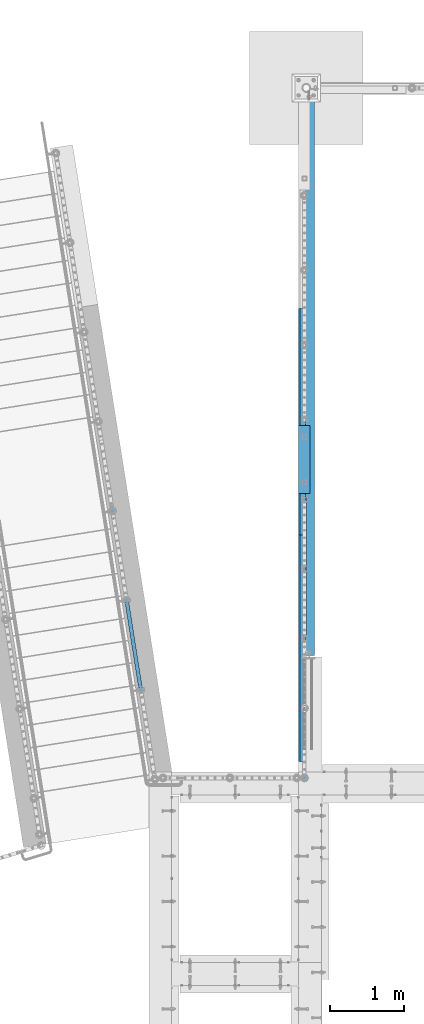
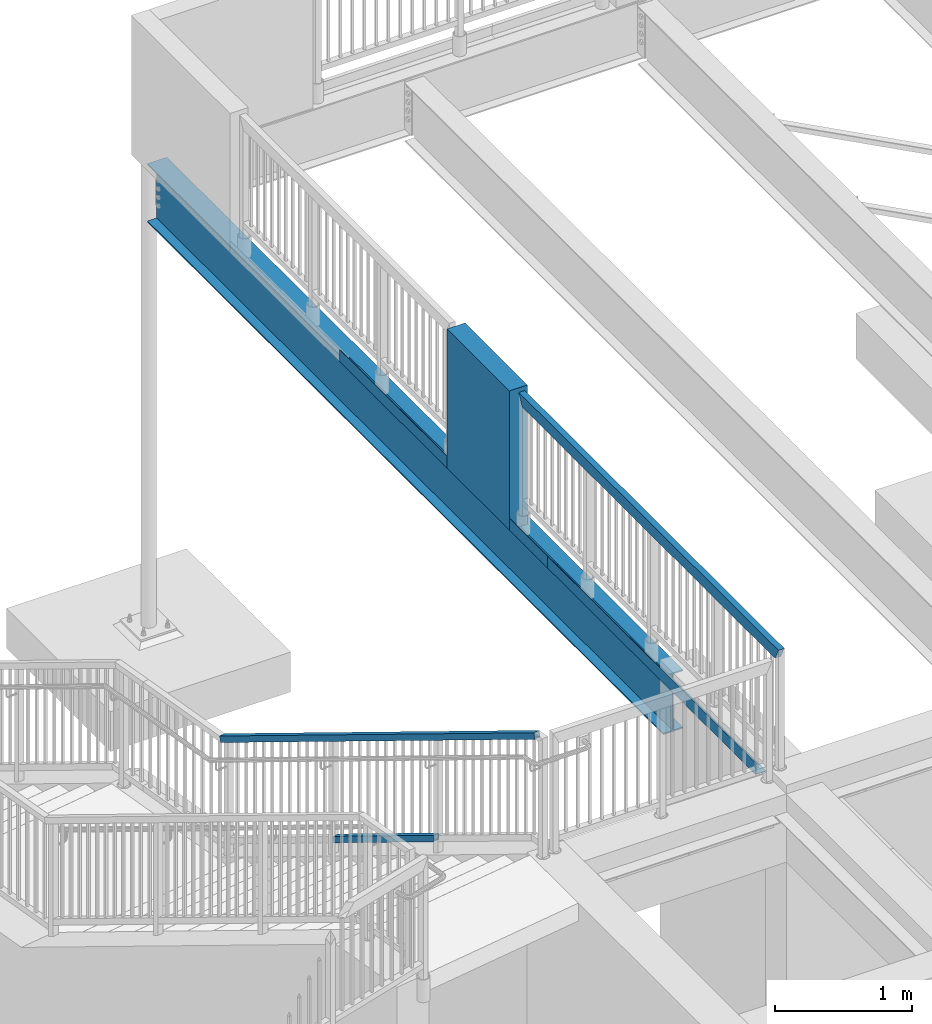
# One storey, part 322 of 975: 5 beams, 2 members.
"""IFC2X3 building model written with IfcOpenShell, lengths in millimetres."""

import ifcopenshell
import ifcopenshell.guid

model = None  # the IFC model being written
_history = None  # IfcOwnerHistory: only IFC2X3 demands one
_inside = {}  # id of a spatial element -> (the spatial element, [elements in it])
_under = {}  # id of a project, library or spatial element -> (it, [spatial elements below it])
_declared = {}  # id of a project -> (the project, [libraries it declares])
_typed = {}  # id of a type object -> (the type object, [elements of that type])
_made_of = {}  # id of a material, layer set ... -> (it, [elements and type objects made of it])


def new_model(schema):
    """Start an empty IFC model of exactly this schema.

    Asked for "IFC4X3", IfcOpenShell would pick the latest addendum, in which some entities
    have other attributes; the version numbers below select the first issue.
    IFC2X3 requires an IfcOwnerHistory on every rooted entity: one is made here for all.
    """
    global model, _history
    if schema == "IFC4X3":
        model = ifcopenshell.file(schema_version=(4, 3, 0, 0))
    else:
        model = ifcopenshell.file(schema=schema)
    _inside.clear()
    _under.clear()
    _declared.clear()
    _typed.clear()
    _made_of.clear()
    _history = None
    if model.schema == "IFC2X3":
        org = make("IfcOrganization", Name="unknown")
        user = make(
            "IfcPersonAndOrganization",
            ThePerson=make("IfcPerson", FamilyName="unknown"),
            TheOrganization=org,
        )
        app = make(
            "IfcApplication",
            ApplicationDeveloper=org,
            Version="unknown",
            ApplicationFullName="unknown",
            ApplicationIdentifier="unknown",
        )
        _history = make(
            "IfcOwnerHistory",
            OwningUser=user,
            OwningApplication=app,
            ChangeAction="ADDED",
            CreationDate=0,
        )
    return model


def make(cls, **values):
    """One entity of the class cls with the attributes given. An attribute that is None is left unset."""
    return model.create_entity(
        cls, **{name: value for name, value in values.items() if value is not None}
    )


def rooted(cls, **values):
    """An entity with a GlobalId (a new one), such as an element, a storey or a relation."""
    return make(cls, GlobalId=ifcopenshell.guid.new(), OwnerHistory=_history, **values)


def si_unit(unit_type, name, prefix=None):
    """IfcSIUnit, for example si_unit("LENGTHUNIT", "METRE", prefix="MILLI")."""
    return make("IfcSIUnit", UnitType=unit_type, Prefix=prefix, Name=name)


def assignment(units):
    """IfcUnitAssignment: the units of a project."""
    return None if units is None else make("IfcUnitAssignment", Units=units)


def point(xyz):
    """IfcCartesianPoint."""
    return None if xyz is None else make("IfcCartesianPoint", Coordinates=xyz)


def direction(xyz):
    """IfcDirection."""
    return None if xyz is None else make("IfcDirection", DirectionRatios=xyz)


def frame(location, z_axis=None, x_axis=None):
    """IfcAxis2Placement3D, a coordinate frame: its origin and axes. An axis left out is left unset."""
    return make(
        "IfcAxis2Placement3D",
        Location=point(location),
        Axis=direction(z_axis),
        RefDirection=direction(x_axis),
    )


def origin_with_axes():
    """The frame at (0, 0, 0) with the z axis (0, 0, 1) and the x axis (1, 0, 0) written out."""
    return frame((0.0, 0.0, 0.0), z_axis=(0.0, 0.0, 1.0), x_axis=(1.0, 0.0, 0.0))


def place(relative_to, where):
    """IfcLocalPlacement: puts the frame where relative to a parent placement (None: the world)."""
    return make(
        "IfcLocalPlacement", PlacementRelTo=relative_to, RelativePlacement=where
    )


def context(
    kind, dimensions, precision=None, world=None, true_north=None, identifier=None
):
    """IfcGeometricRepresentationContext, for example the 3D "Model" context."""
    return make(
        "IfcGeometricRepresentationContext",
        ContextIdentifier=identifier,
        ContextType=kind,
        CoordinateSpaceDimension=dimensions,
        Precision=precision,
        WorldCoordinateSystem=world,
        TrueNorth=true_north,
    )


def subcontext(parent, identifier, kind, view, scale=None):
    """IfcGeometricRepresentationSubContext, for example "Body" below "Model"."""
    return make(
        "IfcGeometricRepresentationSubContext",
        ContextIdentifier=identifier,
        ContextType=kind,
        ParentContext=parent,
        TargetScale=scale,
        TargetView=view,
    )


def project(units=None, contexts=None):
    """IfcProject with its units and contexts."""
    return rooted(
        "IfcProject",
        Name="project",
        RepresentationContexts=contexts,
        UnitsInContext=assignment(units),
    )


def spatial(cls, under=None, at=None, **own):
    """A site, building, storey or space (cls), placed at a placement, below another one or the project."""
    s = rooted(cls, ObjectPlacement=at, **own)
    if under is not None:
        _under.setdefault(under.id(), (under, []))[1].append(s)
    return s


def faces_of(points, faces, orient=None, outer=None):
    """IfcFace entities. A face is a list of loops; a loop is a list of indices into points, from 0.

    orient and outer hold one flag for each loop. By default every Orientation is true, the
    first loop of a face is its IfcFaceOuterBound and the others are IfcFaceBound.
    """
    made = []
    for i, loops in enumerate(faces):
        bounds = []
        for j, loop in enumerate(loops):
            is_outer = j == 0 if outer is None else outer[i][j]
            bounds.append(
                make(
                    "IfcFaceOuterBound" if is_outer else "IfcFaceBound",
                    Bound=make("IfcPolyLoop", Polygon=[points[k] for k in loop]),
                    Orientation=True if orient is None else orient[i][j],
                )
            )
        made.append(make("IfcFace", Bounds=bounds))
    return made


def faceted_brep(points, faces, orient=None, outer=None, voids=None):
    """IfcFacetedBrep: a solid bounded by flat faces; with voids (closed shells), ...WithVoids."""
    shared = [point(p) for p in points]
    hull = make("IfcClosedShell", CfsFaces=faces_of(shared, faces, orient, outer))
    if voids is None:
        return make("IfcFacetedBrep", Outer=hull)
    return make(
        "IfcFacetedBrepWithVoids",
        Outer=hull,
        Voids=[
            make(cls, CfsFaces=faces_of(shared, fs, o, b)) for cls, fs, o, b in voids
        ],
    )


def shape(context_of_items, identifier, shape_type, items):
    """IfcShapeRepresentation: the items that make up one representation, for example the "Body"."""
    return make(
        "IfcShapeRepresentation",
        ContextOfItems=context_of_items,
        RepresentationIdentifier=identifier,
        RepresentationType=shape_type,
        Items=items,
    )


def material(Name=None, Category=None):
    """IfcMaterial."""
    return make("IfcMaterial", Name=Name, Category=Category)


def made_of(thing, what):
    """Note that an element or type object is made of a material, layer set ...; save() writes the relation."""
    if what is not None:
        _made_of.setdefault(what.id(), (what, []))[1].append(thing)
    return thing


def type_object(cls, material=None, **own):
    """A type object (cls), such as IfcWallType, which elements share."""
    return made_of(rooted(cls, **own), material)


def element(
    cls,
    number,
    at=None,
    inside=None,
    cuts=None,
    type_object=None,
    material=None,
    context=None,
    identifier="Body",
    shape_type=None,
    held_by="IfcProductDefinitionShape",
    body=None,
    shapes=None,
    **own,
):
    """One element of the class cls, such as IfcWall. Its Tag is "e" and its number.

    at: its placement. inside: the storey or other place that contains it. cuts: it is an
    opening in that element (IfcRelVoidsElement). A single representation is given by context,
    identifier, shape_type and body (its items); several are given by shapes. held_by: the class
    of the entity that holds the representations. save() writes the other relations.
    """
    e = rooted(cls, Tag="e%d" % number, ObjectPlacement=at, **own)
    if body is not None:
        shapes = [shape(context, identifier, shape_type, body)]
    if shapes is not None:
        e.Representation = make(held_by, Representations=shapes)
    if inside is not None:
        _inside.setdefault(inside.id(), (inside, []))[1].append(e)
    if cuts is not None:
        rooted(
            "IfcRelVoidsElement", RelatingBuildingElement=cuts, RelatedOpeningElement=e
        )
    if type_object is not None:
        _typed.setdefault(type_object.id(), (type_object, []))[1].append(e)
    return made_of(e, material)


def aggregate(whole, parts):
    """IfcRelAggregates: a whole, such as a stair, and the parts it consists of."""
    return rooted("IfcRelAggregates", RelatingObject=whole, RelatedObjects=parts)


def save(model, path):
    """Write the relations noted so far, then the file.

    IfcRelAggregates (storeys below a building ...), IfcRelContainedInSpatialStructure (elements
    in a storey), IfcRelDefinesByType, IfcRelAssociatesMaterial and IfcRelDeclares: one each for
    every whole, place, type object, material and project.
    """
    for whole, parts in _under.values():
        aggregate(whole, parts)
    for where, things in _inside.values():
        rooted(
            "IfcRelContainedInSpatialStructure",
            RelatedElements=things,
            RelatingStructure=where,
        )
    for kind, things in _typed.values():
        rooted("IfcRelDefinesByType", RelatedObjects=things, RelatingType=kind)
    for what, things in _made_of.values():
        rooted("IfcRelAssociatesMaterial", RelatedObjects=things, RelatingMaterial=what)
    for by, libraries in _declared.values():
        rooted("IfcRelDeclares", RelatingContext=by, RelatedDefinitions=libraries)
    model.write(path)


model = new_model("IFC2X3")

# Units and contexts
model_context = context("Model", 3, precision=1e-05, world=origin_with_axes())
body_context = subcontext(model_context, "Body", "Model", "MODEL_VIEW")
ifc_project = project(units=[si_unit("LENGTHUNIT", "METRE", prefix="MILLI"), si_unit("AREAUNIT", "SQUARE_METRE"), si_unit("VOLUMEUNIT", "CUBIC_METRE"), si_unit("MASSUNIT", "GRAM", prefix="KILO"), si_unit("TIMEUNIT", "SECOND"), si_unit("PLANEANGLEUNIT", "RADIAN"), si_unit("SOLIDANGLEUNIT", "STERADIAN"), si_unit("THERMODYNAMICTEMPERATUREUNIT", "DEGREE_CELSIUS"), si_unit("LUMINOUSINTENSITYUNIT", "LUMEN")], contexts=[model_context])

# Site, building, storey
site_placement = place(None, origin_with_axes())
site = spatial("IfcSite", under=ifc_project, at=site_placement, CompositionType="ELEMENT")
building_placement = place(site_placement, origin_with_axes())
building = spatial("IfcBuilding", under=site, at=building_placement, Name="Undefined", CompositionType="ELEMENT")
storey_placement = place(building_placement, origin_with_axes())
storey = spatial("IfcBuildingStorey", under=building, at=storey_placement, Name="Undefined", CompositionType="ELEMENT", Elevation=0.0)

# Members
ifc_material_1 = material()
member_type = type_object("IfcMemberType", Name="HSS2X2X.188_TUBES", PredefinedType="NOTDEFINED")
member_1_placement = place(storey_placement, frame((-177.866716424485, 22282.140450392, 3301.51877837469), z_axis=(0.987688352468583, 0.156434390074216, -6.09999983468464e-08), x_axis=(-0.136949714005939, 0.864666463037498, -0.48331840802096)))
element("IfcMember", 1, at=member_1_placement, inside=storey, type_object=member_type, material=ifc_material_1, Name="HANDRAIL", ObjectType="HSS2X2X.188_TUBES", context=body_context, shape_type="Brep", body=[
    faceted_brep([(-471.980848165029, 20.6375000002809, -20.637499999882), (-449.193607949474, -20.6374999997443, -20.637499999893), (885.442470157759, -20.6375000004718, -20.6375000002081), (862.655229942204, 20.6374999995533, -20.6375000001972), (-449.193607961006, -20.6374999997734, 20.6375000000999), (885.442470146227, -20.6375000005009, 20.6374999997847), (-471.980848176558, 20.6375000002536, 20.6375000001108), (862.655229930675, 20.6374999995278, 20.6374999997961), (-474.610145111648, 25.400000000287, -25.3999999998805), (-474.610145125833, 25.4000000002543, 25.400000000111), (860.025932981403, 25.3999999995285, 25.3999999997964), (860.025932995588, 25.3999999995594, -25.4000000001952), (-446.564311014386, -25.3999999997814, 25.400000000097), (888.07176709285, -25.4000000005053, 25.3999999997823), (-446.564311000198, -25.399999999745, -25.3999999998941), (888.071767107034, -25.4000000004708, -25.4000000002084)], [[[0, 1, 2, 3]], [[1, 4, 5, 2]], [[4, 6, 7, 5]], [[6, 0, 3, 7]], [[8, 9, 10, 11]], [[9, 12, 13, 10]], [[12, 14, 15, 13]], [[14, 8, 11, 15]], [[13, 15, 11, 10], [5, 7, 3, 2]], [[14, 12, 9, 8], [6, 4, 1, 0]]]),
])
member_2_placement = place(storey_placement, frame((69.9090356571271, 20717.7459172887, 5083.16375357614), z_axis=(0.987688352468583, 0.156434390074216, -6.09999983468464e-08), x_axis=(-0.136949714005939, 0.864666463037498, -0.48331840802096)))
element("IfcMember", 2, at=member_2_placement, inside=storey, type_object=member_type, material=ifc_material_1, Name="HANDRAIL", ObjectType="HSS2X2X.188_TUBES", context=body_context, shape_type="Brep", body=[
    faceted_brep([(1.22733805137614, 20.6375000000317, -20.6374999999935), (11.864264413236, -20.6375000000044, -20.6375000000012), (4189.85529292848, -20.6374999997443, -20.6374999999111), (4179.21849778725, 20.6375000002226, -20.6374999999175), (11.8642640556318, -20.6375000000298, 20.6374999999916), (4189.85529301714, -20.6374999997224, 20.6375000000908), (1.2273376937701, 20.6375000000044, 20.6374999999994), (4179.21849787591, 20.6375000002445, 20.6375000000839), (0.0, 25.3999999999724, -25.4000000000342), (0.0, 25.400000000016, 25.4000000000196), (4177.99117536985, 25.4000000002434, 25.4000000000842), (4177.99117526073, 25.4000000002161, -25.3999999999182), (13.0916016715055, -25.4000000000397, 25.3999999999892), (4191.08261554367, -25.3999999997141, 25.4000000000919), (13.0916021116373, -25.4000000000051, -25.4000000000015), (4191.08261543455, -25.3999999997413, -25.3999999999105)], [[[0, 1, 2, 3]], [[1, 4, 5, 2]], [[4, 6, 7, 5]], [[6, 0, 3, 7]], [[8, 9, 10, 11]], [[9, 12, 13, 10]], [[12, 14, 15, 13]], [[14, 8, 11, 15]], [[13, 15, 11, 10], [5, 7, 3, 2]], [[14, 12, 9, 8], [6, 4, 1, 0]]]),
])

# Beams
beam_type_1 = type_object("IfcBeamType", Name="HSS2X4X.188_TUBES", PredefinedType="NOTDEFINED")
beam_1_placement = place(storey_placement, frame((2091.72299802521, 20818.4707157981, 5130.8), z_axis=(0.0, 0.0, 1.0), x_axis=(6.89909999737289e-05, 0.999999997620121, 0.0)))
element("IfcBeam", 3, at=beam_1_placement, inside=storey, type_object=beam_type_1, material=ifc_material_1, Name="GUARDRAIL", ObjectType="HSS2X4X.188_TUBES", context=body_context, shape_type="Brep", body=[
    faceted_brep([(-123.02966101755, 20.6374999999834, -46.0375000000004), (-123.029661038243, -20.6375000000244, -46.0375000000004), (3583.78090900187, -20.6374999994068, -46.0375000000004), (3583.78090900193, 20.6375000006005, -46.0375000000004), (-169.070337085548, -20.6375000000317, 46.0375000000004), (3629.82158494624, -20.6374999993996, 46.0375000000004), (-169.070337064852, 20.6374999999757, 46.0375000000004), (3629.82158494629, 20.6375000006078, 46.0375000000004), (-120.648246736851, 25.3999999999846, -50.8000000000002), (-171.451751340774, 25.399999999976, 50.8000000000002), (3632.20299921929, 25.4000000006095, 50.8000000000002), (3581.39949472895, 25.4000000006013, -50.8000000000002), (-171.451751366243, -25.4000000000333, 50.8000000000002), (3632.20299921922, -25.3999999994003, 50.8000000000002), (-120.648246762325, -25.4000000000251, -50.8000000000002), (3581.39949472888, -25.3999999994085, -50.8000000000002)], [[[0, 1, 2, 3]], [[1, 4, 5, 2]], [[4, 6, 7, 5]], [[6, 0, 3, 7]], [[8, 9, 10, 11]], [[9, 12, 13, 10]], [[12, 14, 15, 13]], [[14, 8, 11, 15]], [[13, 15, 11, 10], [5, 7, 3, 2]], [[14, 12, 9, 8], [6, 4, 1, 0]]]),
])
ifc_material_2 = material(Name="STEEL/A36")
beam_type_2 = type_object("IfcBeamType", PredefinedType="NOTDEFINED")
for number, where, z_axis, x_axis, name in (
    (4, (2105.02499923706, 22418.7534148703, 3938.58749694824), (0.0, 1.0, 0.0), (-0.999999999999998, 6.90000001668524e-08, 0.0), "DECK_EDGE"),
    (5, (2105.02499923706, 25466.7534148703, 3938.58749694824), (0.0, 1.0, 0.0), (-0.999999999999998, 6.90000001668524e-08, 0.0), "DECK_EDGE"),
):
    element("IfcBeam", number, at=place(storey_placement, frame(where, z_axis=z_axis, x_axis=x_axis)), inside=storey, type_object=beam_type_2, material=ifc_material_2, Name=name, context=body_context, shape_type="Brep", body=[
        faceted_brep([(1.03318598121405e-09, -1.58750000000009, -1524.00000000109), (-1.04046193882823e-09, -1.58750000000009, 1524.0000000011), (-1.04046193882823e-09, 1.58750000000009, 1524.0000000011), (1.03318598121405e-09, 1.58750000000009, -1524.00000000109), (85.7250061035156, 1.58750000000009, 1524.0), (85.7250061035156, 1.58750000000009, -1524.0), (88.9000061035158, -1.58750000000009, -1524.0), (88.9000061035158, -1.58750000000009, 1524.0), (85.7250061035156, 96.8375000000005, 1524.0), (85.7250061035156, 96.8375000000005, -1524.0), (88.9000061035158, 104.502628060535, -1524.0), (88.9000061035158, 104.502628060535, 1524.0), (76.7447509765625, 87.857244873047, 1524.0), (76.7447509765625, 87.857244873047, -1524.0), (74.4996869462952, 90.1023089033147, 1524.0), (74.4996869462952, 90.1023089033147, -1524.0)], [[[0, 1, 2, 3]], [[3, 2, 4, 5]], [[1, 0, 6, 7]], [[5, 4, 8, 9]], [[7, 6, 10, 11]], [[9, 8, 12, 13]], [[8, 4, 2, 1, 7, 11, 14, 12]], [[11, 10, 15, 14]], [[10, 6, 0, 3, 5, 9, 13, 15]], [[14, 15, 13, 12]]]),
    ])
ifc_material_3 = material(Name="CONCRETE/5000")
beam_type_3 = type_object("IfcBeamType", PredefinedType="NOTDEFINED")
beam_2_placement = place(storey_placement, frame((2092.325, 25415.875, 4559.3), z_axis=(0.0, 0.0, 1.0), x_axis=(0.0, -1.0, 0.0)))
element("IfcBeam", 6, at=beam_2_placement, inside=storey, type_object=beam_type_3, material=ifc_material_3, Name="LOW WALL", context=body_context, shape_type="Brep", body=[
    faceted_brep([(1.0550138540566e-10, 76.1999999999316, -622.3), (1.0550138540566e-10, 76.1999999999316, 622.3), (914.399999999998, 76.1999999999998, 622.3), (914.399999999998, 76.1999999999998, -622.3), (-1.01863406598568e-10, -76.1999999999243, 622.3), (914.399999999998, -76.2, 622.3), (-1.01863406598568e-10, -76.1999999999243, -622.3), (914.399999999998, -76.2, -622.3)], [[[0, 1, 2, 3]], [[1, 4, 5, 2]], [[4, 6, 7, 5]], [[6, 0, 3, 7]], [[5, 7, 3, 2]], [[6, 4, 1, 0]]]),
])
ifc_material_4 = material(Name="STEEL/A992")
beam_type_4 = type_object("IfcBeamType", Name="W21X44", PredefinedType="NOTDEFINED")
beam_3_placement = place(storey_placement, frame((2143.125, 22298.025, 3675.0625), z_axis=(0.0, 0.0, 1.0), x_axis=(0.0, 1.0, 0.0)))
element("IfcBeam", 7, at=beam_3_placement, inside=storey, type_object=beam_type_4, material=ifc_material_4, Name="BEAM", ObjectType="W21X44", context=body_context, shape_type="Brep", body=[
    faceted_brep([(25.4000000000015, -82.5499999999993, -261.9375), (25.4000000000015, 82.5499999999993, -261.9375), (7581.89999999999, 82.5500000000002, -261.9375), (7581.89999999999, -82.5500000000002, -261.9375), (25.4000000000015, -82.5499999999993, -250.825), (25.4000000000015, -4.76250000000073, -250.825), (25.4000000000015, -4.76250000000073, 250.825), (25.4000000000015, -82.5499999999993, 250.825), (25.4000000000015, -82.5499999999993, 261.9375), (25.4000000000015, 82.5499999999993, 261.9375), (25.4000000000015, 82.5499999999993, 250.825), (25.4000000000015, 4.76250000000073, 250.825), (25.4000000000015, 4.76250000000073, -250.825), (25.4000000000015, 82.5499999999993, -250.825), (7581.89999999999, -82.5500000000002, -250.825), (7581.89999999999, -4.76249999999982, -250.825), (7581.89999999999, -4.76249999999982, 250.825), (7581.89999999999, -82.5500000000002, 250.825), (7581.89999999999, -82.5500000000002, 261.9375), (7581.89999999999, 82.5500000000002, 261.9375), (7581.89999999999, 82.5500000000002, 250.825), (7581.89999999999, 4.76249999999982, 250.825), (7581.89999999999, 4.76249999999982, -250.825), (7581.89999999999, 82.5500000000002, -250.825)], [[[0, 1, 2, 3]], [[0, 4, 5, 6, 7, 8, 9, 10, 11, 12, 13, 1]], [[5, 4, 14, 15]], [[6, 5, 15, 16]], [[7, 6, 16, 17]], [[8, 7, 17, 18]], [[9, 8, 18, 19]], [[10, 9, 19, 20]], [[11, 10, 20, 21]], [[12, 11, 21, 22]], [[13, 12, 22, 23]], [[1, 13, 23, 2]], [[22, 21, 20, 19, 18, 17, 16, 15, 14, 3, 2, 23]], [[4, 0, 3, 14]]]),
])

save(model, "model.ifc")
